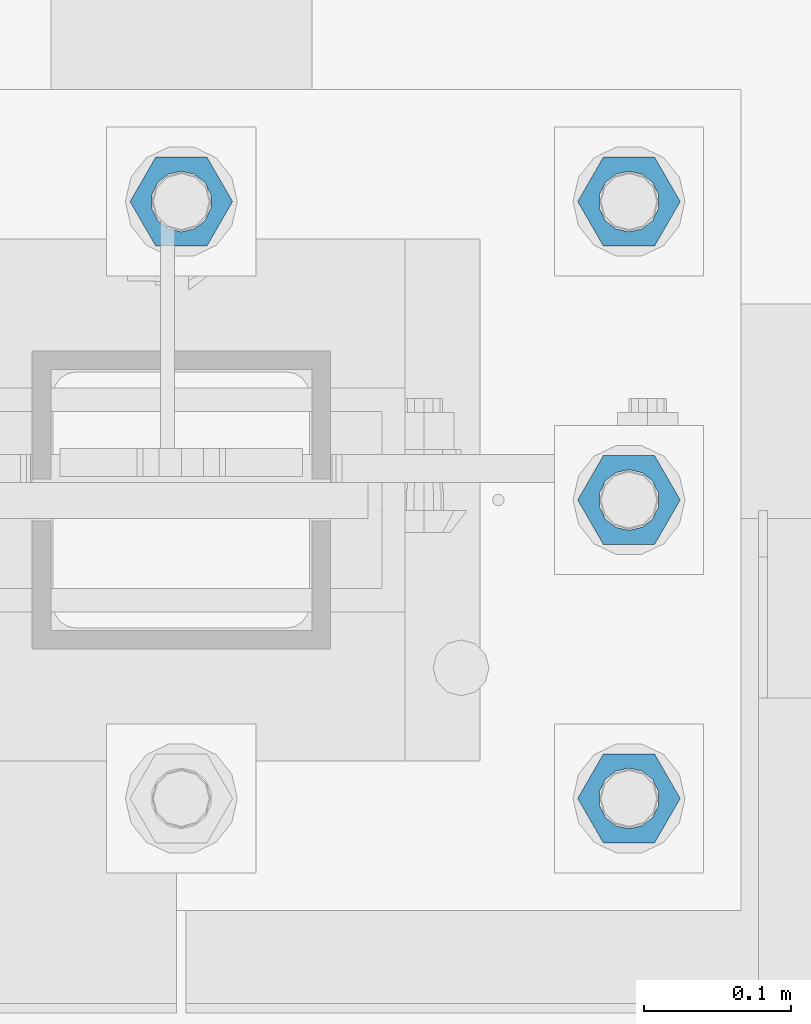
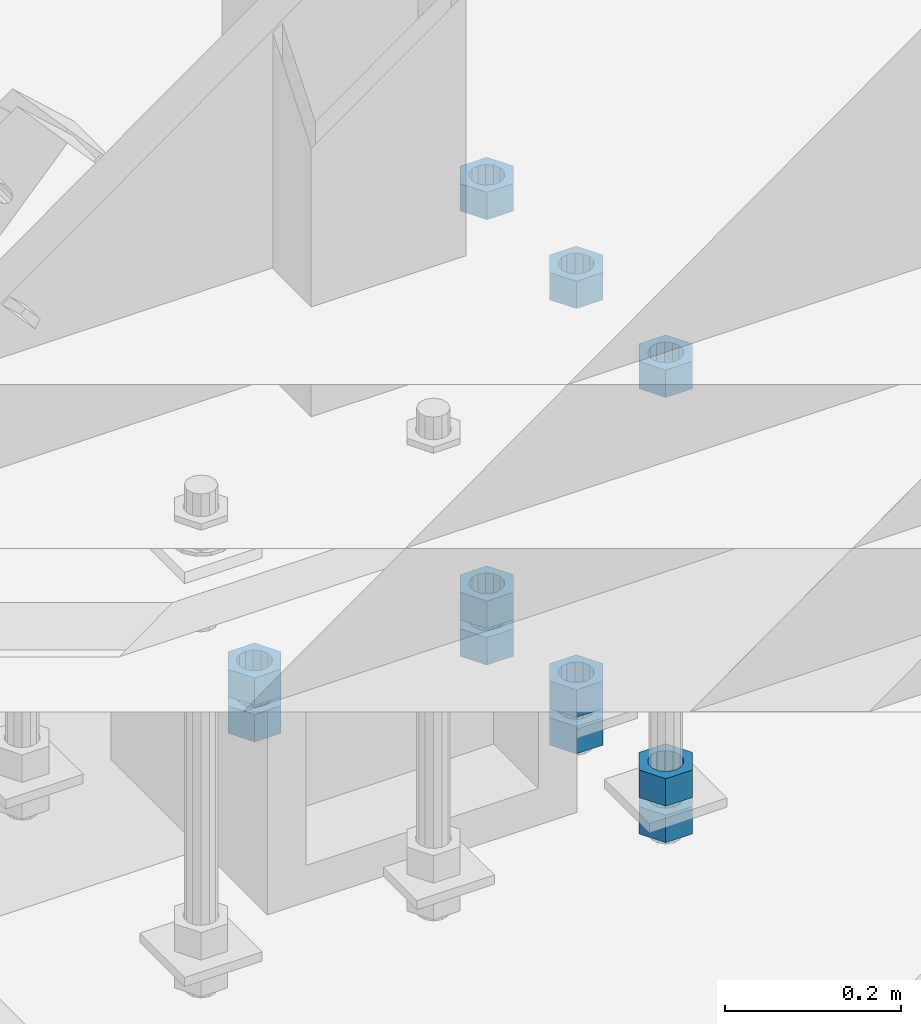
# One storey, part 983 of 1763: 11 columns, 1 element without a shape of its own.
"""IFC2X3 building model written with IfcOpenShell, lengths in millimetres."""

from ifc_helpers import new_model, si_unit, frame, origin_with_axes, place, context, subcontext, project, spatial, faceted_brep, material, type_object, element, aggregate, save


model = new_model("IFC2X3")

# Units and contexts
model_context = context("Model", 3, precision=1e-05, world=origin_with_axes())
body_context = subcontext(model_context, "Body", "Model", "MODEL_VIEW")
ifc_project = project(units=[si_unit("LENGTHUNIT", "METRE", prefix="MILLI"), si_unit("AREAUNIT", "SQUARE_METRE"), si_unit("VOLUMEUNIT", "CUBIC_METRE"), si_unit("MASSUNIT", "GRAM", prefix="KILO"), si_unit("TIMEUNIT", "SECOND"), si_unit("PLANEANGLEUNIT", "RADIAN"), si_unit("SOLIDANGLEUNIT", "STERADIAN"), si_unit("THERMODYNAMICTEMPERATUREUNIT", "DEGREE_CELSIUS"), si_unit("LUMINOUSINTENSITYUNIT", "LUMEN")], contexts=[model_context])

# Site, building, storey
site_placement = place(None, origin_with_axes())
site = spatial("IfcSite", under=ifc_project, at=site_placement, CompositionType="ELEMENT")
building_placement = place(site_placement, origin_with_axes())
building = spatial("IfcBuilding", under=site, at=building_placement, Name="Undefined", CompositionType="ELEMENT")
storey_placement = place(building_placement, origin_with_axes())
storey = spatial("IfcBuildingStorey", under=building, at=storey_placement, Name="Undefined", CompositionType="ELEMENT", Elevation=0.0)

# Assembly, columns
assembly_placement = place(storey_placement, origin_with_axes())
assembly = element("IfcElementAssembly", 1, at=assembly_placement, inside=storey, Name="TEMPLATE", AssemblyPlace="NOTDEFINED", PredefinedType="RIGID_FRAME")
ifc_material = material(Name="STEEL/A563")
column_type = type_object("IfcColumnType", Name="1-1/2_HEAVY_HEX_NUT", PredefinedType="NOTDEFINED")
column_1_placement = place(assembly_placement, frame((-72186.2372736984, -13919.2, 5189.5375), z_axis=(0.0, 1.0, 0.0), x_axis=(0.0, 0.0, -1.0)))
column_1 = element("IfcColumn", 2, at=column_1_placement, type_object=column_type, material=ifc_material, Name="NUT", ObjectType="1-1/2_HEAVY_HEX_NUT", context=body_context, shape_type="Brep", body=[
    faceted_brep([(0.0, -34.9199981689453, 0.0), (0.0, -17.4599990844727, -30.25), (38.1000000000004, -17.4599990844727, -30.25), (38.1000000000004, -34.9199981689453, 0.0), (0.0, 17.4599990844727, -30.25), (38.1000000000004, 17.4599990844727, -30.25), (0.0, 34.9199981689453, 0.0), (38.1000000000004, 34.9199981689453, 0.0), (0.0, 17.4599990844727, 30.25), (38.1000000000004, 17.4599990844727, 30.25), (0.0, -17.4599990844727, 30.25), (38.1000000000004, -17.4599990844727, 30.25), (0.0, 0.0, 20.6399993896484), (0.0, 8.95536011056538, 18.5959968835978), (38.1000000000004, 8.95536011056538, 18.5959968835978), (38.1000000000004, 0.0, 20.6399993896484), (0.0, 16.1370013209453, 12.8688291298167), (38.1000000000004, 16.1370013209453, 12.8688291298167), (0.0, 20.1225115123816, 4.59283194104137), (38.1000000000004, 20.1225115123816, 4.59283194104137), (0.0, 20.1225115123816, -4.59283194104319), (38.1000000000004, 20.1225115123816, -4.59283194104319), (0.0, 16.1370013209453, -12.8688291298167), (38.1000000000004, 16.1370013209453, -12.8688291298167), (0.0, 8.95536011056538, -18.5959968835978), (38.1000000000004, 8.95536011056538, -18.5959968835978), (0.0, 0.0, -20.6399993896484), (38.1000000000004, 0.0, -20.6399993896484), (0.0, -8.95536011056538, -18.5959968835978), (38.1000000000004, -8.95536011056538, -18.5959968835978), (0.0, -16.1370013209453, -12.8688291298167), (38.1000000000004, -16.1370013209453, -12.8688291298167), (0.0, -20.1225115123816, -4.59283194104137), (38.1000000000004, -20.1225115123816, -4.59283194104137), (0.0, -20.1225115123816, 4.59283194104319), (38.1000000000004, -20.1225115123816, 4.59283194104319), (0.0, -16.1370013209453, 12.8688291298167), (38.1000000000004, -16.1370013209453, 12.8688291298167), (0.0, -8.95536011056538, 18.5959968835978), (38.1000000000004, -8.95536011056538, 18.5959968835978)], [[[0, 1, 2, 3]], [[1, 4, 5, 2]], [[4, 6, 7, 5]], [[6, 8, 9, 7]], [[8, 10, 11, 9]], [[10, 0, 3, 11]], [[12, 13, 14, 15]], [[13, 16, 17, 14]], [[16, 18, 19, 17]], [[18, 20, 21, 19]], [[20, 22, 23, 21]], [[22, 24, 25, 23]], [[24, 26, 27, 25]], [[26, 28, 29, 27]], [[28, 30, 31, 29]], [[30, 32, 33, 31]], [[32, 34, 35, 33]], [[34, 36, 37, 35]], [[36, 38, 39, 37]], [[38, 12, 15, 39]], [[5, 7, 9, 11, 3, 2], [17, 19, 21, 23, 25, 27, 29, 31, 33, 35, 37, 39, 15, 14]], [[10, 8, 6, 4, 1, 0], [38, 36, 34, 32, 30, 28, 26, 24, 22, 20, 18, 16, 13, 12]]]),
])
column_2_placement = place(assembly_placement, frame((-72186.2372736984, -13919.2, 4622.8), z_axis=(0.0, 1.0, 0.0), x_axis=(0.0, 0.0, -1.0)))
column_2 = element("IfcColumn", 3, at=column_2_placement, type_object=column_type, material=ifc_material, Name="NUT", ObjectType="1-1/2_HEAVY_HEX_NUT", context=body_context, shape_type="Brep", body=[
    faceted_brep([(0.0, -34.9199981689453, 0.0), (0.0, -17.4599990844727, -30.25), (38.1000000000004, -17.4599990844727, -30.25), (38.1000000000004, -34.9199981689453, 0.0), (0.0, 17.4599990844727, -30.25), (38.1000000000004, 17.4599990844727, -30.25), (0.0, 34.9199981689453, 0.0), (38.1000000000004, 34.9199981689453, 0.0), (0.0, 17.4599990844727, 30.25), (38.1000000000004, 17.4599990844727, 30.25), (0.0, -17.4599990844727, 30.25), (38.1000000000004, -17.4599990844727, 30.25), (0.0, 0.0, 20.6399993896484), (0.0, 8.95536011056538, 18.5959968835978), (38.1000000000004, 8.95536011056538, 18.5959968835978), (38.1000000000004, 0.0, 20.6399993896484), (0.0, 16.1370013209453, 12.8688291298167), (38.1000000000004, 16.1370013209453, 12.8688291298167), (0.0, 20.1225115123816, 4.59283194104137), (38.1000000000004, 20.1225115123816, 4.59283194104137), (0.0, 20.1225115123816, -4.59283194104319), (38.1000000000004, 20.1225115123816, -4.59283194104319), (0.0, 16.1370013209453, -12.8688291298167), (38.1000000000004, 16.1370013209453, -12.8688291298167), (0.0, 8.95536011056538, -18.5959968835978), (38.1000000000004, 8.95536011056538, -18.5959968835978), (0.0, 0.0, -20.6399993896484), (38.1000000000004, 0.0, -20.6399993896484), (0.0, -8.95536011056538, -18.5959968835978), (38.1000000000004, -8.95536011056538, -18.5959968835978), (0.0, -16.1370013209453, -12.8688291298167), (38.1000000000004, -16.1370013209453, -12.8688291298167), (0.0, -20.1225115123816, -4.59283194104137), (38.1000000000004, -20.1225115123816, -4.59283194104137), (0.0, -20.1225115123816, 4.59283194104319), (38.1000000000004, -20.1225115123816, 4.59283194104319), (0.0, -16.1370013209453, 12.8688291298167), (38.1000000000004, -16.1370013209453, 12.8688291298167), (0.0, -8.95536011056538, 18.5959968835978), (38.1000000000004, -8.95536011056538, 18.5959968835978)], [[[0, 1, 2, 3]], [[1, 4, 5, 2]], [[4, 6, 7, 5]], [[6, 8, 9, 7]], [[8, 10, 11, 9]], [[10, 0, 3, 11]], [[12, 13, 14, 15]], [[13, 16, 17, 14]], [[16, 18, 19, 17]], [[18, 20, 21, 19]], [[20, 22, 23, 21]], [[22, 24, 25, 23]], [[24, 26, 27, 25]], [[26, 28, 29, 27]], [[28, 30, 31, 29]], [[30, 32, 33, 31]], [[32, 34, 35, 33]], [[34, 36, 37, 35]], [[36, 38, 39, 37]], [[38, 12, 15, 39]], [[5, 7, 9, 11, 3, 2], [17, 19, 21, 23, 25, 27, 29, 31, 33, 35, 37, 39, 15, 14]], [[10, 8, 6, 4, 1, 0], [38, 36, 34, 32, 30, 28, 26, 24, 22, 20, 18, 16, 13, 12]]]),
])
column_3_placement = place(assembly_placement, frame((-72186.2372736984, -13919.2, 4572.0), z_axis=(0.0, 1.0, 0.0), x_axis=(0.0, 0.0, -1.0)))
column_3 = element("IfcColumn", 4, at=column_3_placement, type_object=column_type, material=ifc_material, Name="NUT", ObjectType="1-1/2_HEAVY_HEX_NUT", context=body_context, shape_type="Brep", body=[
    faceted_brep([(0.0, -34.9199981689453, 0.0), (0.0, -17.4599990844727, -30.25), (38.1000000000004, -17.4599990844727, -30.25), (38.1000000000004, -34.9199981689453, 0.0), (0.0, 17.4599990844727, -30.25), (38.1000000000004, 17.4599990844727, -30.25), (0.0, 34.9199981689453, 0.0), (38.1000000000004, 34.9199981689453, 0.0), (0.0, 17.4599990844727, 30.25), (38.1000000000004, 17.4599990844727, 30.25), (0.0, -17.4599990844727, 30.25), (38.1000000000004, -17.4599990844727, 30.25), (0.0, 0.0, 20.6399993896484), (0.0, 8.95536011056538, 18.5959968835978), (38.1000000000004, 8.95536011056538, 18.5959968835978), (38.1000000000004, 0.0, 20.6399993896484), (0.0, 16.1370013209453, 12.8688291298167), (38.1000000000004, 16.1370013209453, 12.8688291298167), (0.0, 20.1225115123816, 4.59283194104137), (38.1000000000004, 20.1225115123816, 4.59283194104137), (0.0, 20.1225115123816, -4.59283194104319), (38.1000000000004, 20.1225115123816, -4.59283194104319), (0.0, 16.1370013209453, -12.8688291298167), (38.1000000000004, 16.1370013209453, -12.8688291298167), (0.0, 8.95536011056538, -18.5959968835978), (38.1000000000004, 8.95536011056538, -18.5959968835978), (0.0, 0.0, -20.6399993896484), (38.1000000000004, 0.0, -20.6399993896484), (0.0, -8.95536011056538, -18.5959968835978), (38.1000000000004, -8.95536011056538, -18.5959968835978), (0.0, -16.1370013209453, -12.8688291298167), (38.1000000000004, -16.1370013209453, -12.8688291298167), (0.0, -20.1225115123816, -4.59283194104137), (38.1000000000004, -20.1225115123816, -4.59283194104137), (0.0, -20.1225115123816, 4.59283194104319), (38.1000000000004, -20.1225115123816, 4.59283194104319), (0.0, -16.1370013209453, 12.8688291298167), (38.1000000000004, -16.1370013209453, 12.8688291298167), (0.0, -8.95536011056538, 18.5959968835978), (38.1000000000004, -8.95536011056538, 18.5959968835978)], [[[0, 1, 2, 3]], [[1, 4, 5, 2]], [[4, 6, 7, 5]], [[6, 8, 9, 7]], [[8, 10, 11, 9]], [[10, 0, 3, 11]], [[12, 13, 14, 15]], [[13, 16, 17, 14]], [[16, 18, 19, 17]], [[18, 20, 21, 19]], [[20, 22, 23, 21]], [[22, 24, 25, 23]], [[24, 26, 27, 25]], [[26, 28, 29, 27]], [[28, 30, 31, 29]], [[30, 32, 33, 31]], [[32, 34, 35, 33]], [[34, 36, 37, 35]], [[36, 38, 39, 37]], [[38, 12, 15, 39]], [[5, 7, 9, 11, 3, 2], [17, 19, 21, 23, 25, 27, 29, 31, 33, 35, 37, 39, 15, 14]], [[10, 8, 6, 4, 1, 0], [38, 36, 34, 32, 30, 28, 26, 24, 22, 20, 18, 16, 13, 12]]]),
])
column_4_placement = place(assembly_placement, frame((-72186.2372736984, -13716.0, 5189.5375), z_axis=(0.0, 1.0, 0.0), x_axis=(0.0, 0.0, -1.0)))
column_4 = element("IfcColumn", 5, at=column_4_placement, type_object=column_type, material=ifc_material, Name="NUT", ObjectType="1-1/2_HEAVY_HEX_NUT", context=body_context, shape_type="Brep", body=[
    faceted_brep([(0.0, -34.9199981689453, 0.0), (0.0, -17.4599990844727, -30.25), (38.1000000000004, -17.4599990844727, -30.25), (38.1000000000004, -34.9199981689453, 0.0), (0.0, 17.4599990844727, -30.25), (38.1000000000004, 17.4599990844727, -30.25), (0.0, 34.9199981689453, 0.0), (38.1000000000004, 34.9199981689453, 0.0), (0.0, 17.4599990844727, 30.25), (38.1000000000004, 17.4599990844727, 30.25), (0.0, -17.4599990844727, 30.25), (38.1000000000004, -17.4599990844727, 30.25), (0.0, 0.0, 20.6399993896484), (0.0, 8.95536011056538, 18.5959968835978), (38.1000000000004, 8.95536011056538, 18.5959968835978), (38.1000000000004, 0.0, 20.6399993896484), (0.0, 16.1370013209453, 12.8688291298167), (38.1000000000004, 16.1370013209453, 12.8688291298167), (0.0, 20.1225115123816, 4.59283194104137), (38.1000000000004, 20.1225115123816, 4.59283194104137), (0.0, 20.1225115123816, -4.59283194104319), (38.1000000000004, 20.1225115123816, -4.59283194104319), (0.0, 16.1370013209453, -12.8688291298167), (38.1000000000004, 16.1370013209453, -12.8688291298167), (0.0, 8.95536011056538, -18.5959968835978), (38.1000000000004, 8.95536011056538, -18.5959968835978), (0.0, 0.0, -20.6399993896484), (38.1000000000004, 0.0, -20.6399993896484), (0.0, -8.95536011056538, -18.5959968835978), (38.1000000000004, -8.95536011056538, -18.5959968835978), (0.0, -16.1370013209453, -12.8688291298167), (38.1000000000004, -16.1370013209453, -12.8688291298167), (0.0, -20.1225115123816, -4.59283194104137), (38.1000000000004, -20.1225115123816, -4.59283194104137), (0.0, -20.1225115123816, 4.59283194104319), (38.1000000000004, -20.1225115123816, 4.59283194104319), (0.0, -16.1370013209453, 12.8688291298167), (38.1000000000004, -16.1370013209453, 12.8688291298167), (0.0, -8.95536011056538, 18.5959968835978), (38.1000000000004, -8.95536011056538, 18.5959968835978)], [[[0, 1, 2, 3]], [[1, 4, 5, 2]], [[4, 6, 7, 5]], [[6, 8, 9, 7]], [[8, 10, 11, 9]], [[10, 0, 3, 11]], [[12, 13, 14, 15]], [[13, 16, 17, 14]], [[16, 18, 19, 17]], [[18, 20, 21, 19]], [[20, 22, 23, 21]], [[22, 24, 25, 23]], [[24, 26, 27, 25]], [[26, 28, 29, 27]], [[28, 30, 31, 29]], [[30, 32, 33, 31]], [[32, 34, 35, 33]], [[34, 36, 37, 35]], [[36, 38, 39, 37]], [[38, 12, 15, 39]], [[5, 7, 9, 11, 3, 2], [17, 19, 21, 23, 25, 27, 29, 31, 33, 35, 37, 39, 15, 14]], [[10, 8, 6, 4, 1, 0], [38, 36, 34, 32, 30, 28, 26, 24, 22, 20, 18, 16, 13, 12]]]),
])
column_5_placement = place(assembly_placement, frame((-72186.2372736984, -13716.0, 4622.8), z_axis=(0.0, 1.0, 0.0), x_axis=(0.0, 0.0, -1.0)))
column_5 = element("IfcColumn", 6, at=column_5_placement, type_object=column_type, material=ifc_material, Name="NUT", ObjectType="1-1/2_HEAVY_HEX_NUT", context=body_context, shape_type="Brep", body=[
    faceted_brep([(0.0, -34.9199981689453, 0.0), (0.0, -17.4599990844727, -30.25), (38.1000000000004, -17.4599990844727, -30.25), (38.1000000000004, -34.9199981689453, 0.0), (0.0, 17.4599990844727, -30.25), (38.1000000000004, 17.4599990844727, -30.25), (0.0, 34.9199981689453, 0.0), (38.1000000000004, 34.9199981689453, 0.0), (0.0, 17.4599990844727, 30.25), (38.1000000000004, 17.4599990844727, 30.25), (0.0, -17.4599990844727, 30.25), (38.1000000000004, -17.4599990844727, 30.25), (0.0, 0.0, 20.6399993896484), (0.0, 8.95536011056538, 18.5959968835978), (38.1000000000004, 8.95536011056538, 18.5959968835978), (38.1000000000004, 0.0, 20.6399993896484), (0.0, 16.1370013209453, 12.8688291298167), (38.1000000000004, 16.1370013209453, 12.8688291298167), (0.0, 20.1225115123816, 4.59283194104137), (38.1000000000004, 20.1225115123816, 4.59283194104137), (0.0, 20.1225115123816, -4.59283194104319), (38.1000000000004, 20.1225115123816, -4.59283194104319), (0.0, 16.1370013209453, -12.8688291298167), (38.1000000000004, 16.1370013209453, -12.8688291298167), (0.0, 8.95536011056538, -18.5959968835978), (38.1000000000004, 8.95536011056538, -18.5959968835978), (0.0, 0.0, -20.6399993896484), (38.1000000000004, 0.0, -20.6399993896484), (0.0, -8.95536011056538, -18.5959968835978), (38.1000000000004, -8.95536011056538, -18.5959968835978), (0.0, -16.1370013209453, -12.8688291298167), (38.1000000000004, -16.1370013209453, -12.8688291298167), (0.0, -20.1225115123816, -4.59283194104137), (38.1000000000004, -20.1225115123816, -4.59283194104137), (0.0, -20.1225115123816, 4.59283194104319), (38.1000000000004, -20.1225115123816, 4.59283194104319), (0.0, -16.1370013209453, 12.8688291298167), (38.1000000000004, -16.1370013209453, 12.8688291298167), (0.0, -8.95536011056538, 18.5959968835978), (38.1000000000004, -8.95536011056538, 18.5959968835978)], [[[0, 1, 2, 3]], [[1, 4, 5, 2]], [[4, 6, 7, 5]], [[6, 8, 9, 7]], [[8, 10, 11, 9]], [[10, 0, 3, 11]], [[12, 13, 14, 15]], [[13, 16, 17, 14]], [[16, 18, 19, 17]], [[18, 20, 21, 19]], [[20, 22, 23, 21]], [[22, 24, 25, 23]], [[24, 26, 27, 25]], [[26, 28, 29, 27]], [[28, 30, 31, 29]], [[30, 32, 33, 31]], [[32, 34, 35, 33]], [[34, 36, 37, 35]], [[36, 38, 39, 37]], [[38, 12, 15, 39]], [[5, 7, 9, 11, 3, 2], [17, 19, 21, 23, 25, 27, 29, 31, 33, 35, 37, 39, 15, 14]], [[10, 8, 6, 4, 1, 0], [38, 36, 34, 32, 30, 28, 26, 24, 22, 20, 18, 16, 13, 12]]]),
])
column_6_placement = place(assembly_placement, frame((-72186.2372736984, -13716.0, 4572.0), z_axis=(0.0, 1.0, 0.0), x_axis=(0.0, 0.0, -1.0)))
column_6 = element("IfcColumn", 7, at=column_6_placement, type_object=column_type, material=ifc_material, Name="NUT", ObjectType="1-1/2_HEAVY_HEX_NUT", context=body_context, shape_type="Brep", body=[
    faceted_brep([(0.0, -34.9199981689453, 0.0), (0.0, -17.4599990844727, -30.25), (38.1000000000004, -17.4599990844727, -30.25), (38.1000000000004, -34.9199981689453, 0.0), (0.0, 17.4599990844727, -30.25), (38.1000000000004, 17.4599990844727, -30.25), (0.0, 34.9199981689453, 0.0), (38.1000000000004, 34.9199981689453, 0.0), (0.0, 17.4599990844727, 30.25), (38.1000000000004, 17.4599990844727, 30.25), (0.0, -17.4599990844727, 30.25), (38.1000000000004, -17.4599990844727, 30.25), (0.0, 0.0, 20.6399993896484), (0.0, 8.95536011056538, 18.5959968835978), (38.1000000000004, 8.95536011056538, 18.5959968835978), (38.1000000000004, 0.0, 20.6399993896484), (0.0, 16.1370013209453, 12.8688291298167), (38.1000000000004, 16.1370013209453, 12.8688291298167), (0.0, 20.1225115123816, 4.59283194104137), (38.1000000000004, 20.1225115123816, 4.59283194104137), (0.0, 20.1225115123816, -4.59283194104319), (38.1000000000004, 20.1225115123816, -4.59283194104319), (0.0, 16.1370013209453, -12.8688291298167), (38.1000000000004, 16.1370013209453, -12.8688291298167), (0.0, 8.95536011056538, -18.5959968835978), (38.1000000000004, 8.95536011056538, -18.5959968835978), (0.0, 0.0, -20.6399993896484), (38.1000000000004, 0.0, -20.6399993896484), (0.0, -8.95536011056538, -18.5959968835978), (38.1000000000004, -8.95536011056538, -18.5959968835978), (0.0, -16.1370013209453, -12.8688291298167), (38.1000000000004, -16.1370013209453, -12.8688291298167), (0.0, -20.1225115123816, -4.59283194104137), (38.1000000000004, -20.1225115123816, -4.59283194104137), (0.0, -20.1225115123816, 4.59283194104319), (38.1000000000004, -20.1225115123816, 4.59283194104319), (0.0, -16.1370013209453, 12.8688291298167), (38.1000000000004, -16.1370013209453, 12.8688291298167), (0.0, -8.95536011056538, 18.5959968835978), (38.1000000000004, -8.95536011056538, 18.5959968835978)], [[[0, 1, 2, 3]], [[1, 4, 5, 2]], [[4, 6, 7, 5]], [[6, 8, 9, 7]], [[8, 10, 11, 9]], [[10, 0, 3, 11]], [[12, 13, 14, 15]], [[13, 16, 17, 14]], [[16, 18, 19, 17]], [[18, 20, 21, 19]], [[20, 22, 23, 21]], [[22, 24, 25, 23]], [[24, 26, 27, 25]], [[26, 28, 29, 27]], [[28, 30, 31, 29]], [[30, 32, 33, 31]], [[32, 34, 35, 33]], [[34, 36, 37, 35]], [[36, 38, 39, 37]], [[38, 12, 15, 39]], [[5, 7, 9, 11, 3, 2], [17, 19, 21, 23, 25, 27, 29, 31, 33, 35, 37, 39, 15, 14]], [[10, 8, 6, 4, 1, 0], [38, 36, 34, 32, 30, 28, 26, 24, 22, 20, 18, 16, 13, 12]]]),
])
column_7_placement = place(assembly_placement, frame((-72491.0372736984, -13512.8, 4622.8), z_axis=(0.0, 1.0, 0.0), x_axis=(0.0, 0.0, -1.0)))
column_7 = element("IfcColumn", 8, at=column_7_placement, type_object=column_type, material=ifc_material, Name="NUT", ObjectType="1-1/2_HEAVY_HEX_NUT", context=body_context, shape_type="Brep", body=[
    faceted_brep([(0.0, -34.9199981689453, 0.0), (0.0, -17.4599990844727, -30.25), (38.1000000000004, -17.4599990844727, -30.25), (38.1000000000004, -34.9199981689453, 0.0), (0.0, 17.4599990844727, -30.25), (38.1000000000004, 17.4599990844727, -30.25), (0.0, 34.9199981689453, 0.0), (38.1000000000004, 34.9199981689453, 0.0), (0.0, 17.4599990844727, 30.25), (38.1000000000004, 17.4599990844727, 30.25), (0.0, -17.4599990844727, 30.25), (38.1000000000004, -17.4599990844727, 30.25), (0.0, 0.0, 20.6399993896484), (0.0, 8.95536011056538, 18.5959968835978), (38.1000000000004, 8.95536011056538, 18.5959968835978), (38.1000000000004, 0.0, 20.6399993896484), (0.0, 16.1370013209453, 12.8688291298167), (38.1000000000004, 16.1370013209453, 12.8688291298167), (0.0, 20.1225115123816, 4.59283194104137), (38.1000000000004, 20.1225115123816, 4.59283194104137), (0.0, 20.1225115123816, -4.59283194104319), (38.1000000000004, 20.1225115123816, -4.59283194104319), (0.0, 16.1370013209453, -12.8688291298167), (38.1000000000004, 16.1370013209453, -12.8688291298167), (0.0, 8.95536011056538, -18.5959968835978), (38.1000000000004, 8.95536011056538, -18.5959968835978), (0.0, 0.0, -20.6399993896484), (38.1000000000004, 0.0, -20.6399993896484), (0.0, -8.95536011056538, -18.5959968835978), (38.1000000000004, -8.95536011056538, -18.5959968835978), (0.0, -16.1370013209453, -12.8688291298167), (38.1000000000004, -16.1370013209453, -12.8688291298167), (0.0, -20.1225115123816, -4.59283194104137), (38.1000000000004, -20.1225115123816, -4.59283194104137), (0.0, -20.1225115123816, 4.59283194104319), (38.1000000000004, -20.1225115123816, 4.59283194104319), (0.0, -16.1370013209453, 12.8688291298167), (38.1000000000004, -16.1370013209453, 12.8688291298167), (0.0, -8.95536011056538, 18.5959968835978), (38.1000000000004, -8.95536011056538, 18.5959968835978)], [[[0, 1, 2, 3]], [[1, 4, 5, 2]], [[4, 6, 7, 5]], [[6, 8, 9, 7]], [[8, 10, 11, 9]], [[10, 0, 3, 11]], [[12, 13, 14, 15]], [[13, 16, 17, 14]], [[16, 18, 19, 17]], [[18, 20, 21, 19]], [[20, 22, 23, 21]], [[22, 24, 25, 23]], [[24, 26, 27, 25]], [[26, 28, 29, 27]], [[28, 30, 31, 29]], [[30, 32, 33, 31]], [[32, 34, 35, 33]], [[34, 36, 37, 35]], [[36, 38, 39, 37]], [[38, 12, 15, 39]], [[5, 7, 9, 11, 3, 2], [17, 19, 21, 23, 25, 27, 29, 31, 33, 35, 37, 39, 15, 14]], [[10, 8, 6, 4, 1, 0], [38, 36, 34, 32, 30, 28, 26, 24, 22, 20, 18, 16, 13, 12]]]),
])
column_8_placement = place(assembly_placement, frame((-72491.0372736984, -13512.8, 4572.0), z_axis=(0.0, 1.0, 0.0), x_axis=(0.0, 0.0, -1.0)))
column_8 = element("IfcColumn", 9, at=column_8_placement, type_object=column_type, material=ifc_material, Name="NUT", ObjectType="1-1/2_HEAVY_HEX_NUT", context=body_context, shape_type="Brep", body=[
    faceted_brep([(0.0, -34.9199981689453, 0.0), (0.0, -17.4599990844727, -30.25), (38.1000000000004, -17.4599990844727, -30.25), (38.1000000000004, -34.9199981689453, 0.0), (0.0, 17.4599990844727, -30.25), (38.1000000000004, 17.4599990844727, -30.25), (0.0, 34.9199981689453, 0.0), (38.1000000000004, 34.9199981689453, 0.0), (0.0, 17.4599990844727, 30.25), (38.1000000000004, 17.4599990844727, 30.25), (0.0, -17.4599990844727, 30.25), (38.1000000000004, -17.4599990844727, 30.25), (0.0, 0.0, 20.6399993896484), (0.0, 8.95536011056538, 18.5959968835978), (38.1000000000004, 8.95536011056538, 18.5959968835978), (38.1000000000004, 0.0, 20.6399993896484), (0.0, 16.1370013209453, 12.8688291298167), (38.1000000000004, 16.1370013209453, 12.8688291298167), (0.0, 20.1225115123816, 4.59283194104137), (38.1000000000004, 20.1225115123816, 4.59283194104137), (0.0, 20.1225115123816, -4.59283194104319), (38.1000000000004, 20.1225115123816, -4.59283194104319), (0.0, 16.1370013209453, -12.8688291298167), (38.1000000000004, 16.1370013209453, -12.8688291298167), (0.0, 8.95536011056538, -18.5959968835978), (38.1000000000004, 8.95536011056538, -18.5959968835978), (0.0, 0.0, -20.6399993896484), (38.1000000000004, 0.0, -20.6399993896484), (0.0, -8.95536011056538, -18.5959968835978), (38.1000000000004, -8.95536011056538, -18.5959968835978), (0.0, -16.1370013209453, -12.8688291298167), (38.1000000000004, -16.1370013209453, -12.8688291298167), (0.0, -20.1225115123816, -4.59283194104137), (38.1000000000004, -20.1225115123816, -4.59283194104137), (0.0, -20.1225115123816, 4.59283194104319), (38.1000000000004, -20.1225115123816, 4.59283194104319), (0.0, -16.1370013209453, 12.8688291298167), (38.1000000000004, -16.1370013209453, 12.8688291298167), (0.0, -8.95536011056538, 18.5959968835978), (38.1000000000004, -8.95536011056538, 18.5959968835978)], [[[0, 1, 2, 3]], [[1, 4, 5, 2]], [[4, 6, 7, 5]], [[6, 8, 9, 7]], [[8, 10, 11, 9]], [[10, 0, 3, 11]], [[12, 13, 14, 15]], [[13, 16, 17, 14]], [[16, 18, 19, 17]], [[18, 20, 21, 19]], [[20, 22, 23, 21]], [[22, 24, 25, 23]], [[24, 26, 27, 25]], [[26, 28, 29, 27]], [[28, 30, 31, 29]], [[30, 32, 33, 31]], [[32, 34, 35, 33]], [[34, 36, 37, 35]], [[36, 38, 39, 37]], [[38, 12, 15, 39]], [[5, 7, 9, 11, 3, 2], [17, 19, 21, 23, 25, 27, 29, 31, 33, 35, 37, 39, 15, 14]], [[10, 8, 6, 4, 1, 0], [38, 36, 34, 32, 30, 28, 26, 24, 22, 20, 18, 16, 13, 12]]]),
])
column_9_placement = place(assembly_placement, frame((-72186.2372736984, -13512.8, 5189.5375), z_axis=(0.0, 1.0, 0.0), x_axis=(0.0, 0.0, -1.0)))
column_9 = element("IfcColumn", 10, at=column_9_placement, type_object=column_type, material=ifc_material, Name="NUT", ObjectType="1-1/2_HEAVY_HEX_NUT", context=body_context, shape_type="Brep", body=[
    faceted_brep([(0.0, -34.9199981689453, 0.0), (0.0, -17.4599990844727, -30.25), (38.1000000000004, -17.4599990844727, -30.25), (38.1000000000004, -34.9199981689453, 0.0), (0.0, 17.4599990844727, -30.25), (38.1000000000004, 17.4599990844727, -30.25), (0.0, 34.9199981689453, 0.0), (38.1000000000004, 34.9199981689453, 0.0), (0.0, 17.4599990844727, 30.25), (38.1000000000004, 17.4599990844727, 30.25), (0.0, -17.4599990844727, 30.25), (38.1000000000004, -17.4599990844727, 30.25), (0.0, 0.0, 20.6399993896484), (0.0, 8.95536011056538, 18.5959968835978), (38.1000000000004, 8.95536011056538, 18.5959968835978), (38.1000000000004, 0.0, 20.6399993896484), (0.0, 16.1370013209453, 12.8688291298167), (38.1000000000004, 16.1370013209453, 12.8688291298167), (0.0, 20.1225115123816, 4.59283194104137), (38.1000000000004, 20.1225115123816, 4.59283194104137), (0.0, 20.1225115123816, -4.59283194104319), (38.1000000000004, 20.1225115123816, -4.59283194104319), (0.0, 16.1370013209453, -12.8688291298167), (38.1000000000004, 16.1370013209453, -12.8688291298167), (0.0, 8.95536011056538, -18.5959968835978), (38.1000000000004, 8.95536011056538, -18.5959968835978), (0.0, 0.0, -20.6399993896484), (38.1000000000004, 0.0, -20.6399993896484), (0.0, -8.95536011056538, -18.5959968835978), (38.1000000000004, -8.95536011056538, -18.5959968835978), (0.0, -16.1370013209453, -12.8688291298167), (38.1000000000004, -16.1370013209453, -12.8688291298167), (0.0, -20.1225115123816, -4.59283194104137), (38.1000000000004, -20.1225115123816, -4.59283194104137), (0.0, -20.1225115123816, 4.59283194104319), (38.1000000000004, -20.1225115123816, 4.59283194104319), (0.0, -16.1370013209453, 12.8688291298167), (38.1000000000004, -16.1370013209453, 12.8688291298167), (0.0, -8.95536011056538, 18.5959968835978), (38.1000000000004, -8.95536011056538, 18.5959968835978)], [[[0, 1, 2, 3]], [[1, 4, 5, 2]], [[4, 6, 7, 5]], [[6, 8, 9, 7]], [[8, 10, 11, 9]], [[10, 0, 3, 11]], [[12, 13, 14, 15]], [[13, 16, 17, 14]], [[16, 18, 19, 17]], [[18, 20, 21, 19]], [[20, 22, 23, 21]], [[22, 24, 25, 23]], [[24, 26, 27, 25]], [[26, 28, 29, 27]], [[28, 30, 31, 29]], [[30, 32, 33, 31]], [[32, 34, 35, 33]], [[34, 36, 37, 35]], [[36, 38, 39, 37]], [[38, 12, 15, 39]], [[5, 7, 9, 11, 3, 2], [17, 19, 21, 23, 25, 27, 29, 31, 33, 35, 37, 39, 15, 14]], [[10, 8, 6, 4, 1, 0], [38, 36, 34, 32, 30, 28, 26, 24, 22, 20, 18, 16, 13, 12]]]),
])
column_10_placement = place(assembly_placement, frame((-72186.2372736984, -13512.8, 4622.8), z_axis=(0.0, 1.0, 0.0), x_axis=(0.0, 0.0, -1.0)))
column_10 = element("IfcColumn", 11, at=column_10_placement, type_object=column_type, material=ifc_material, Name="NUT", ObjectType="1-1/2_HEAVY_HEX_NUT", context=body_context, shape_type="Brep", body=[
    faceted_brep([(0.0, -34.9199981689453, 0.0), (0.0, -17.4599990844727, -30.25), (38.1000000000004, -17.4599990844727, -30.25), (38.1000000000004, -34.9199981689453, 0.0), (0.0, 17.4599990844727, -30.25), (38.1000000000004, 17.4599990844727, -30.25), (0.0, 34.9199981689453, 0.0), (38.1000000000004, 34.9199981689453, 0.0), (0.0, 17.4599990844727, 30.25), (38.1000000000004, 17.4599990844727, 30.25), (0.0, -17.4599990844727, 30.25), (38.1000000000004, -17.4599990844727, 30.25), (0.0, 0.0, 20.6399993896484), (0.0, 8.95536011056538, 18.5959968835978), (38.1000000000004, 8.95536011056538, 18.5959968835978), (38.1000000000004, 0.0, 20.6399993896484), (0.0, 16.1370013209453, 12.8688291298167), (38.1000000000004, 16.1370013209453, 12.8688291298167), (0.0, 20.1225115123816, 4.59283194104137), (38.1000000000004, 20.1225115123816, 4.59283194104137), (0.0, 20.1225115123816, -4.59283194104319), (38.1000000000004, 20.1225115123816, -4.59283194104319), (0.0, 16.1370013209453, -12.8688291298167), (38.1000000000004, 16.1370013209453, -12.8688291298167), (0.0, 8.95536011056538, -18.5959968835978), (38.1000000000004, 8.95536011056538, -18.5959968835978), (0.0, 0.0, -20.6399993896484), (38.1000000000004, 0.0, -20.6399993896484), (0.0, -8.95536011056538, -18.5959968835978), (38.1000000000004, -8.95536011056538, -18.5959968835978), (0.0, -16.1370013209453, -12.8688291298167), (38.1000000000004, -16.1370013209453, -12.8688291298167), (0.0, -20.1225115123816, -4.59283194104137), (38.1000000000004, -20.1225115123816, -4.59283194104137), (0.0, -20.1225115123816, 4.59283194104319), (38.1000000000004, -20.1225115123816, 4.59283194104319), (0.0, -16.1370013209453, 12.8688291298167), (38.1000000000004, -16.1370013209453, 12.8688291298167), (0.0, -8.95536011056538, 18.5959968835978), (38.1000000000004, -8.95536011056538, 18.5959968835978)], [[[0, 1, 2, 3]], [[1, 4, 5, 2]], [[4, 6, 7, 5]], [[6, 8, 9, 7]], [[8, 10, 11, 9]], [[10, 0, 3, 11]], [[12, 13, 14, 15]], [[13, 16, 17, 14]], [[16, 18, 19, 17]], [[18, 20, 21, 19]], [[20, 22, 23, 21]], [[22, 24, 25, 23]], [[24, 26, 27, 25]], [[26, 28, 29, 27]], [[28, 30, 31, 29]], [[30, 32, 33, 31]], [[32, 34, 35, 33]], [[34, 36, 37, 35]], [[36, 38, 39, 37]], [[38, 12, 15, 39]], [[5, 7, 9, 11, 3, 2], [17, 19, 21, 23, 25, 27, 29, 31, 33, 35, 37, 39, 15, 14]], [[10, 8, 6, 4, 1, 0], [38, 36, 34, 32, 30, 28, 26, 24, 22, 20, 18, 16, 13, 12]]]),
])
column_11_placement = place(assembly_placement, frame((-72186.2372736984, -13512.8, 4572.0), z_axis=(0.0, 1.0, 0.0), x_axis=(0.0, 0.0, -1.0)))
column_11 = element("IfcColumn", 12, at=column_11_placement, type_object=column_type, material=ifc_material, Name="NUT", ObjectType="1-1/2_HEAVY_HEX_NUT", context=body_context, shape_type="Brep", body=[
    faceted_brep([(0.0, -34.9199981689453, 0.0), (0.0, -17.4599990844727, -30.25), (38.1000000000004, -17.4599990844727, -30.25), (38.1000000000004, -34.9199981689453, 0.0), (0.0, 17.4599990844727, -30.25), (38.1000000000004, 17.4599990844727, -30.25), (0.0, 34.9199981689453, 0.0), (38.1000000000004, 34.9199981689453, 0.0), (0.0, 17.4599990844727, 30.25), (38.1000000000004, 17.4599990844727, 30.25), (0.0, -17.4599990844727, 30.25), (38.1000000000004, -17.4599990844727, 30.25), (0.0, 0.0, 20.6399993896484), (0.0, 8.95536011056538, 18.5959968835978), (38.1000000000004, 8.95536011056538, 18.5959968835978), (38.1000000000004, 0.0, 20.6399993896484), (0.0, 16.1370013209453, 12.8688291298167), (38.1000000000004, 16.1370013209453, 12.8688291298167), (0.0, 20.1225115123816, 4.59283194104137), (38.1000000000004, 20.1225115123816, 4.59283194104137), (0.0, 20.1225115123816, -4.59283194104319), (38.1000000000004, 20.1225115123816, -4.59283194104319), (0.0, 16.1370013209453, -12.8688291298167), (38.1000000000004, 16.1370013209453, -12.8688291298167), (0.0, 8.95536011056538, -18.5959968835978), (38.1000000000004, 8.95536011056538, -18.5959968835978), (0.0, 0.0, -20.6399993896484), (38.1000000000004, 0.0, -20.6399993896484), (0.0, -8.95536011056538, -18.5959968835978), (38.1000000000004, -8.95536011056538, -18.5959968835978), (0.0, -16.1370013209453, -12.8688291298167), (38.1000000000004, -16.1370013209453, -12.8688291298167), (0.0, -20.1225115123816, -4.59283194104137), (38.1000000000004, -20.1225115123816, -4.59283194104137), (0.0, -20.1225115123816, 4.59283194104319), (38.1000000000004, -20.1225115123816, 4.59283194104319), (0.0, -16.1370013209453, 12.8688291298167), (38.1000000000004, -16.1370013209453, 12.8688291298167), (0.0, -8.95536011056538, 18.5959968835978), (38.1000000000004, -8.95536011056538, 18.5959968835978)], [[[0, 1, 2, 3]], [[1, 4, 5, 2]], [[4, 6, 7, 5]], [[6, 8, 9, 7]], [[8, 10, 11, 9]], [[10, 0, 3, 11]], [[12, 13, 14, 15]], [[13, 16, 17, 14]], [[16, 18, 19, 17]], [[18, 20, 21, 19]], [[20, 22, 23, 21]], [[22, 24, 25, 23]], [[24, 26, 27, 25]], [[26, 28, 29, 27]], [[28, 30, 31, 29]], [[30, 32, 33, 31]], [[32, 34, 35, 33]], [[34, 36, 37, 35]], [[36, 38, 39, 37]], [[38, 12, 15, 39]], [[5, 7, 9, 11, 3, 2], [17, 19, 21, 23, 25, 27, 29, 31, 33, 35, 37, 39, 15, 14]], [[10, 8, 6, 4, 1, 0], [38, 36, 34, 32, 30, 28, 26, 24, 22, 20, 18, 16, 13, 12]]]),
])
aggregate(assembly, [column_1, column_2, column_3, column_4, column_5, column_6, column_7, column_8, column_9, column_10, column_11])

save(model, "model.ifc")
